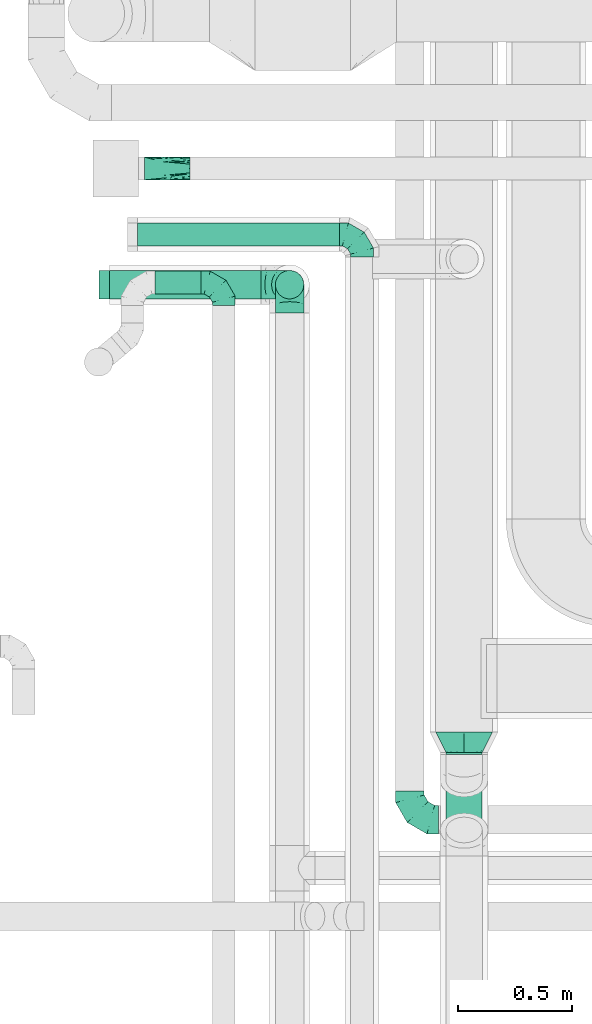
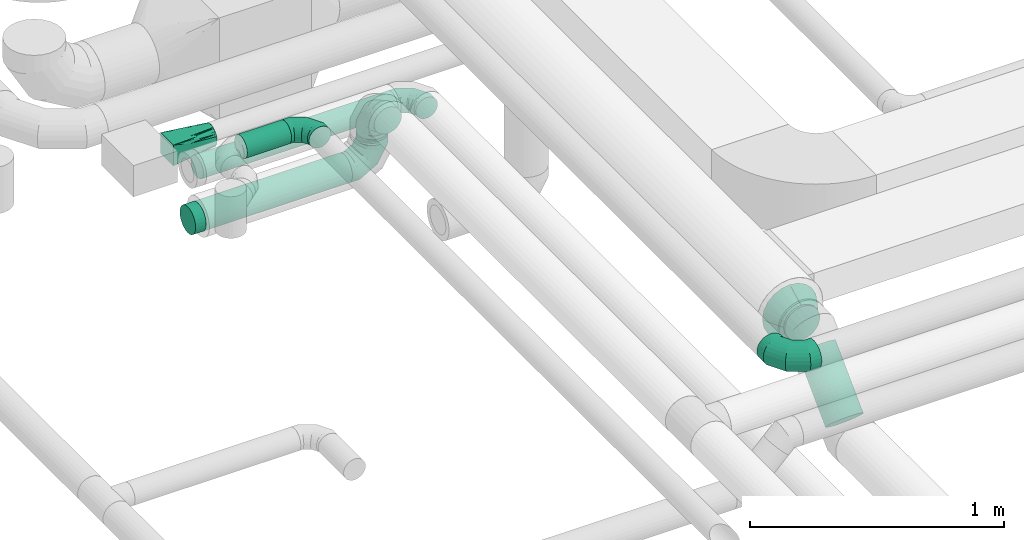
# One storey, part 67 of 92: 8 flow fittings, 6 flow segments.
"""IFC2X3 building model written with IfcOpenShell, lengths in millimetres."""

from ifc_helpers import new_model, entity, si_unit, converted_unit, derived_unit, direction, frame, origin, origin_2d_with_axis, place, context, subcontext, project, spatial, circle, extrude, faceted_brep, source, transform, mapped, material, type_object, type_shapes, element, save


model = new_model("IFC2X3")

# Units and contexts
model_context = context("Model", 3, precision=0.01, world=origin(), true_north=direction((6.12303176911189e-17, 1.0)))
body_context = subcontext(model_context, "Body", "Model", "MODEL_VIEW")
ifc_project = project(units=[si_unit("LENGTHUNIT", "METRE", prefix="MILLI"), si_unit("AREAUNIT", "SQUARE_METRE"), si_unit("VOLUMEUNIT", "CUBIC_METRE"), converted_unit("PLANEANGLEUNIT", "DEGREE", entity("IfcRatioMeasure", 0.0174532925199433), si_unit("PLANEANGLEUNIT", "RADIAN"), dimensions=[0, 0, 0, 0, 0, 0, 0]), si_unit("MASSUNIT", "GRAM", prefix="KILO"), derived_unit("MASSDENSITYUNIT", [(si_unit("MASSUNIT", "GRAM", prefix="KILO"), 1), (si_unit("LENGTHUNIT", "METRE"), -3)]), derived_unit("MOMENTOFINERTIAUNIT", [(si_unit("LENGTHUNIT", "METRE"), 4)]), si_unit("TIMEUNIT", "SECOND"), si_unit("FREQUENCYUNIT", "HERTZ"), si_unit("THERMODYNAMICTEMPERATUREUNIT", "DEGREE_CELSIUS"), derived_unit("THERMALTRANSMITTANCEUNIT", [(si_unit("MASSUNIT", "GRAM", prefix="KILO"), 1), (si_unit("THERMODYNAMICTEMPERATUREUNIT", "KELVIN"), -1), (si_unit("TIMEUNIT", "SECOND"), -3)]), derived_unit("VOLUMETRICFLOWRATEUNIT", [(si_unit("LENGTHUNIT", "METRE"), 3), (si_unit("TIMEUNIT", "SECOND"), -1)]), derived_unit("MASSFLOWRATEUNIT", [(si_unit("MASSUNIT", "GRAM", prefix="KILO"), 1), (si_unit("TIMEUNIT", "SECOND"), -1)]), derived_unit("ROTATIONALFREQUENCYUNIT", [(si_unit("TIMEUNIT", "SECOND"), -1)]), si_unit("ELECTRICCURRENTUNIT", "AMPERE"), si_unit("ELECTRICVOLTAGEUNIT", "VOLT"), si_unit("POWERUNIT", "WATT"), si_unit("FORCEUNIT", "NEWTON", prefix="KILO"), si_unit("ILLUMINANCEUNIT", "LUX"), si_unit("LUMINOUSFLUXUNIT", "LUMEN"), si_unit("LUMINOUSINTENSITYUNIT", "CANDELA"), derived_unit("USERDEFINED", [(si_unit("MASSUNIT", "GRAM", prefix="KILO"), -1), (si_unit("LENGTHUNIT", "METRE"), -2), (si_unit("TIMEUNIT", "SECOND"), 3), (si_unit("LUMINOUSFLUXUNIT", "LUMEN"), 1)]), derived_unit("LINEARVELOCITYUNIT", [(si_unit("LENGTHUNIT", "METRE"), 1), (si_unit("TIMEUNIT", "SECOND"), -1)]), si_unit("PRESSUREUNIT", "PASCAL"), derived_unit("USERDEFINED", [(si_unit("LENGTHUNIT", "METRE"), -2), (si_unit("MASSUNIT", "GRAM", prefix="KILO"), 1), (si_unit("TIMEUNIT", "SECOND"), -2)]), derived_unit("LINEARFORCEUNIT", [(si_unit("MASSUNIT", "GRAM", prefix="KILO"), 1), (si_unit("LENGTHUNIT", "METRE"), 1), (si_unit("TIMEUNIT", "SECOND"), -2), (si_unit("LENGTHUNIT", "METRE"), -1)]), derived_unit("PLANARFORCEUNIT", [(si_unit("MASSUNIT", "GRAM", prefix="KILO"), 1), (si_unit("LENGTHUNIT", "METRE"), 1), (si_unit("TIMEUNIT", "SECOND"), -2), (si_unit("LENGTHUNIT", "METRE"), -2)])], contexts=[model_context])

# Site, building, storey
site_placement = place(None, origin())
site = spatial("IfcSite", under=ifc_project, at=site_placement, CompositionType="ELEMENT")
building_placement = place(site_placement, origin())
building = spatial("IfcBuilding", under=site, at=building_placement, CompositionType="ELEMENT")
storey_placement = place(building_placement, frame((0.0, 0.0, 4200.0)))
storey = spatial("IfcBuildingStorey", under=building, at=storey_placement, CompositionType="ELEMENT", Elevation=4200.0)

# Flow segments
duct_segment_type_1 = type_object("IfcDuctSegmentType", PredefinedType="NOTDEFINED")
flow_segment_1_placement = place(storey_placement, frame((59650.81, 11473.3, 3098.4)))
element("IfcFlowSegment", 1, at=flow_segment_1_placement, inside=storey, type_object=duct_segment_type_1, context=body_context, shape_type="SweptSolid", body=[
    extrude(circle(Radius=50.0, at=origin_2d_with_axis()), frame((0.0, 51.6, 51.6), z_axis=(1.0, 0.0, 0.0), x_axis=(0.0, 1.0, 0.0)), (0.0, 0.0, 1.0), 886.324534692973),
])
flow_segment_2_placement = place(storey_placement, frame((59528.94, 11240.09, 3025.9)))
element("IfcFlowSegment", 2, at=flow_segment_2_placement, inside=storey, type_object=duct_segment_type_1, context=body_context, shape_type="SweptSolid", body=[
    extrude(circle(Radius=62.5, at=origin_2d_with_axis()), frame((0.0, 64.1, 64.1), z_axis=(1.0, 0.0, 0.0), x_axis=(0.0, 1.0, 0.0)), (0.0, 0.0, 1.0), 665.012949999809),
])
flow_segment_3_placement = place(storey_placement, frame((61003.4, 9241.69, 3200.9)))
element("IfcFlowSegment", 3, at=flow_segment_3_placement, inside=storey, type_object=duct_segment_type_1, context=body_context, shape_type="SweptSolid", body=[
    extrude(circle(Radius=80.0, at=origin_2d_with_axis()), frame((81.6, 0.0, 81.6), z_axis=(0.0, 1.0, 0.0), x_axis=(-1.0, 0.0, 0.0)), (0.0, 0.0, 1.0), 9.44565002031431),
])
flow_segment_4_placement = place(storey_placement, frame((61003.4, 8851.62, 2958.7)))
element("IfcFlowSegment", 4, at=flow_segment_4_placement, inside=storey, type_object=duct_segment_type_1, context=body_context, shape_type="SweptSolid", body=[
    extrude(circle(Radius=80.0, at=origin_2d_with_axis()), frame((81.6, 58.16, 58.16), z_axis=(0.0, 0.707106781186505, 0.707106781186591), x_axis=(-1.0, 0.0, 0.0)), (0.0, 0.0, 1.0), 309.3933982822),
])
duct_segment_type_2 = type_object("IfcDuctSegmentType", PredefinedType="NOTDEFINED")
flow_segment_5_placement = place(storey_placement, frame((60254.86, 11240.09, 3215.0)))
element("IfcFlowSegment", 5, at=flow_segment_5_placement, inside=storey, type_object=duct_segment_type_2, context=body_context, shape_type="SweptSolid", body=[
    extrude(circle(Radius=62.5, at=origin_2d_with_axis()), frame((64.1, 64.1, 0.0), z_axis=(0.0, 0.0, 1.0), x_axis=(-1.0, 0.0, 0.0)), (0.0, 0.0, 1.0), 10.0000000000508),
])
flow_segment_6_placement = place(storey_placement, frame((59728.25, 11261.85, 3298.4)))
element("IfcFlowSegment", 6, at=flow_segment_6_placement, inside=storey, type_object=duct_segment_type_2, context=body_context, shape_type="SweptSolid", body=[
    extrude(circle(Radius=50.0, at=origin_2d_with_axis()), frame((0.0, 51.6, 51.6), z_axis=(1.0, 0.0, 0.0), x_axis=(0.0, 1.0, 0.0)), (0.0, 0.0, 1.0), 201.79999999998),
])

# Flow fittings
ifc_material = material()
duct_fitting_type_1 = type_object("IfcDuctFittingType", PredefinedType="NOTDEFINED", material=ifc_material)
shared_shape_1 = source(origin(), body_context, "Body", "Brep", [
    faceted_brep([(-100.0, 0.0, -50.0), (-100.0, -12.94, -48.3), (-100.0, -25.0, -43.3), (-100.0, -35.36, -35.36), (-100.0, -43.3, -25.0), (-100.0, -48.3, -12.94), (-100.0, -50.0, 0.0), (-100.0, -48.3, 12.94), (-100.0, -43.3, 25.0), (-100.0, -35.36, 35.36), (-100.0, -25.0, 43.3), (-100.0, -12.94, 48.3), (-100.0, 0.0, 50.0), (-100.0, 12.94, 48.3), (-100.0, 25.0, 43.3), (-100.0, 35.36, 35.36), (-100.0, 43.3, 25.0), (-100.0, 48.3, 12.94), (-100.0, 50.0, 0.0), (-100.0, 48.3, -12.94), (-100.0, 43.3, -25.0), (-100.0, 35.36, -35.36), (-100.0, 25.0, -43.3), (-100.0, 12.94, -48.3), (-76.67, 12.94, 48.3), (-79.9, 25.0, 43.3), (-73.21, 0.0, 50.0), (-82.68, 35.36, 35.36), (-86.15, 48.3, 12.94), (-86.6, 50.0, 0.0), (-84.81, 43.3, 25.0), (-84.81, 43.3, -25.0), (-82.68, 35.36, -35.36), (-86.15, 48.3, -12.94), (-76.67, 12.94, -48.3), (-73.21, 0.0, -50.0), (-79.9, 25.0, -43.3), (-69.74, -12.94, -48.3), (-66.51, -25.0, -43.3), (-63.73, -35.36, -35.36), (-61.6, -43.3, -25.0), (-60.26, -48.3, -12.94), (-59.81, -50.0, 0.0), (-60.26, -48.3, 12.94), (-61.6, -43.3, 25.0), (-63.73, -35.36, 35.36), (-66.51, -25.0, 43.3), (-69.74, -12.94, 48.3), (-36.27, 36.27, 48.3), (-45.1, 45.1, 43.3), (-26.79, 26.79, 50.0), (-52.68, 52.68, 35.36), (-58.49, 58.49, 25.0), (-62.15, 62.15, 12.94), (-63.4, 63.4, 0.0), (-62.15, 62.15, -12.94), (-58.49, 58.49, -25.0), (-52.68, 52.68, -35.36), (-36.27, 36.27, -48.3), (-26.79, 26.79, -50.0), (-45.1, 45.1, -43.3), (-17.32, 17.32, -48.3), (-8.49, 8.49, -43.3), (-0.91, 0.91, -35.36), (4.9, -4.9, -25.0), (8.56, -8.56, -12.94), (9.81, -9.81, 0.0), (8.56, -8.56, 12.94), (4.9, -4.9, 25.0), (-0.91, 0.91, 35.36), (-8.49, 8.49, 43.3), (-17.32, 17.32, 48.3), (-12.94, 76.67, 48.3), (-25.0, 79.9, 43.3), (0.0, 73.21, 50.0), (-35.36, 82.68, 35.36), (-43.3, 84.81, 25.0), (-48.3, 86.15, 12.94), (-50.0, 86.6, 0.0), (-48.3, 86.15, -12.94), (-43.3, 84.81, -25.0), (-35.36, 82.68, -35.36), (-12.94, 76.67, -48.3), (0.0, 73.21, -50.0), (-25.0, 79.9, -43.3), (12.94, 69.74, -48.3), (25.0, 66.51, -43.3), (35.36, 63.73, -35.36), (43.3, 61.6, -25.0), (48.3, 60.26, -12.94), (50.0, 59.81, 0.0), (48.3, 60.26, 12.94), (43.3, 61.6, 25.0), (35.36, 63.73, 35.36), (25.0, 66.51, 43.3), (12.94, 69.74, 48.3), (-12.94, 100.0, -48.3), (-25.0, 100.0, -43.3), (-35.36, 100.0, -35.36), (-43.3, 100.0, -25.0), (-48.3, 100.0, -12.94), (-50.0, 100.0, 0.0), (-48.3, 100.0, 12.94), (-43.3, 100.0, 25.0), (-35.36, 100.0, 35.36), (-25.0, 100.0, 43.3), (-12.94, 100.0, 48.3), (0.0, 100.0, 50.0), (12.94, 100.0, 48.3), (25.0, 100.0, 43.3), (35.36, 100.0, 35.36), (43.3, 100.0, 25.0), (48.3, 100.0, 12.94), (50.0, 100.0, 0.0), (48.3, 100.0, -12.94), (43.3, 100.0, -25.0), (35.36, 100.0, -35.36), (25.0, 100.0, -43.3), (12.94, 100.0, -48.3), (0.0, 100.0, -50.0)], [[[0, 1, 2, 3, 4, 5, 6, 7, 8, 9, 10, 11, 12, 13, 14, 15, 16, 17, 18, 19, 20, 21, 22, 23]], [[24, 25, 14, 13]], [[26, 24, 13, 12]], [[14, 25, 27, 15]], [[28, 29, 18, 17]], [[30, 28, 17, 16]], [[15, 27, 30, 16]], [[20, 31, 32, 21]], [[33, 31, 20, 19]], [[18, 29, 33, 19]], [[34, 35, 0, 23]], [[36, 34, 23, 22]], [[32, 36, 22, 21]], [[2, 1, 37, 38]], [[3, 2, 38, 39]], [[0, 35, 37, 1]], [[5, 4, 40, 41]], [[6, 5, 41, 42]], [[3, 39, 40, 4]], [[6, 42, 43, 7]], [[7, 43, 44, 8]], [[8, 44, 45, 9]], [[10, 46, 47, 11]], [[11, 47, 26, 12]], [[10, 9, 45, 46]], [[48, 49, 25, 24]], [[50, 48, 24, 26]], [[27, 25, 49, 51]], [[52, 53, 28, 30]], [[51, 52, 30, 27]], [[29, 28, 53, 54]], [[55, 56, 31, 33]], [[54, 55, 33, 29]], [[57, 32, 31, 56]], [[58, 59, 35, 34]], [[60, 58, 34, 36]], [[57, 60, 36, 32]], [[37, 35, 59, 61]], [[38, 37, 61, 62]], [[39, 38, 62, 63]], [[41, 40, 64, 65]], [[42, 41, 65, 66]], [[63, 64, 40, 39]], [[43, 42, 66, 67]], [[44, 43, 67, 68]], [[68, 69, 45, 44]], [[46, 45, 69, 70]], [[47, 46, 70, 71]], [[26, 47, 71, 50]], [[72, 73, 49, 48]], [[74, 72, 48, 50]], [[51, 49, 73, 75]], [[76, 77, 53, 52]], [[75, 76, 52, 51]], [[54, 53, 77, 78]], [[79, 80, 56, 55]], [[78, 79, 55, 54]], [[81, 57, 56, 80]], [[82, 83, 59, 58]], [[84, 82, 58, 60]], [[81, 84, 60, 57]], [[61, 59, 83, 85]], [[62, 61, 85, 86]], [[63, 62, 86, 87]], [[65, 64, 88, 89]], [[66, 65, 89, 90]], [[87, 88, 64, 63]], [[67, 66, 90, 91]], [[68, 67, 91, 92]], [[92, 93, 69, 68]], [[70, 69, 93, 94]], [[71, 70, 94, 95]], [[50, 71, 95, 74]], [[96, 97, 98, 99, 100, 101, 102, 103, 104, 105, 106, 107, 108, 109, 110, 111, 112, 113, 114, 115, 116, 117, 118, 119]], [[72, 74, 107, 106]], [[73, 72, 106, 105]], [[75, 73, 105, 104]], [[77, 76, 103, 102]], [[78, 77, 102, 101]], [[75, 104, 103, 76]], [[78, 101, 100, 79]], [[79, 100, 99, 80]], [[80, 99, 98, 81]], [[96, 119, 83, 82]], [[97, 96, 82, 84]], [[84, 81, 98, 97]], [[83, 119, 118, 85]], [[85, 118, 117, 86]], [[86, 117, 116, 87]], [[88, 115, 114, 89]], [[89, 114, 113, 90]], [[87, 116, 115, 88]], [[91, 90, 113, 112]], [[92, 91, 112, 111]], [[93, 92, 111, 110]], [[95, 94, 109, 108]], [[74, 95, 108, 107]], [[110, 109, 94, 93]]]),
])
type_shapes(duct_fitting_type_1, [shared_shape_1])
for number, where, z_axis, x_axis in (
    (7, (60030.05, 11313.45, 3350.0), (0.0, 0.0, 1.0), (0.0, 1.0, 0.0)),
    (8, (60637.13, 11524.89, 3150.0), (0.0, 0.0, 1.0), (0.0, 1.0, 0.0)),
):
    element("IfcFlowFitting", number, at=place(storey_placement, frame(where, z_axis=z_axis, x_axis=x_axis)), inside=storey, type_object=duct_fitting_type_1, material=ifc_material, context=body_context, shape_type="MappedRepresentation", body=[
        mapped(shared_shape_1, transform((0.0, 0.0, 0.0), scale=1.0)),
    ])
duct_fitting_type_2 = type_object("IfcDuctFittingType", PredefinedType="NOTDEFINED", material=ifc_material)
shared_shape_2 = source(origin(), body_context, "Body", "Brep", [
    faceted_brep([(-125.0, 0.0, -62.5), (-125.0, -16.18, -60.37), (-125.0, -31.25, -54.13), (-125.0, -44.19, -44.19), (-125.0, -54.13, -31.25), (-125.0, -60.37, -16.18), (-125.0, -62.5, 0.0), (-125.0, -60.37, 16.18), (-125.0, -54.13, 31.25), (-125.0, -44.19, 44.19), (-125.0, -31.25, 54.13), (-125.0, -16.18, 60.37), (-125.0, 0.0, 62.5), (-125.0, 16.18, 60.37), (-125.0, 31.25, 54.13), (-125.0, 44.19, 44.19), (-125.0, 54.13, 31.25), (-125.0, 60.37, 16.18), (-125.0, 62.5, 0.0), (-125.0, 60.37, -16.18), (-125.0, 54.13, -31.25), (-125.0, 44.19, -44.19), (-125.0, 31.25, -54.13), (-125.0, 16.18, -60.37), (-95.84, 16.18, 60.37), (-99.88, 31.25, 54.13), (-91.51, 0.0, 62.5), (-103.35, 44.19, 44.19), (-107.68, 60.37, 16.18), (-108.25, 62.5, 0.0), (-106.01, 54.13, 31.25), (-106.01, 54.13, -31.25), (-103.35, 44.19, -44.19), (-107.68, 60.37, -16.18), (-95.84, 16.18, -60.37), (-91.51, 0.0, -62.5), (-99.88, 31.25, -54.13), (-87.17, -16.18, -60.37), (-83.13, -31.25, -54.13), (-79.66, -44.19, -44.19), (-77.0, -54.13, -31.25), (-75.33, -60.37, -16.18), (-74.76, -62.5, 0.0), (-75.33, -60.37, 16.18), (-77.0, -54.13, 31.25), (-79.66, -44.19, 44.19), (-83.13, -31.25, 54.13), (-87.17, -16.18, 60.37), (-45.34, 45.34, 60.37), (-56.37, 56.37, 54.13), (-33.49, 33.49, 62.5), (-65.85, 65.85, 44.19), (-73.12, 73.12, 31.25), (-77.69, 77.69, 16.18), (-79.25, 79.25, 0.0), (-77.69, 77.69, -16.18), (-73.12, 73.12, -31.25), (-65.85, 65.85, -44.19), (-45.34, 45.34, -60.37), (-33.49, 33.49, -62.5), (-56.37, 56.37, -54.13), (-21.65, 21.65, -60.37), (-10.62, 10.62, -54.13), (-1.14, 1.14, -44.19), (6.13, -6.13, -31.25), (10.7, -10.7, -16.18), (12.26, -12.26, 0.0), (10.7, -10.7, 16.18), (6.13, -6.13, 31.25), (-1.14, 1.14, 44.19), (-10.62, 10.62, 54.13), (-21.65, 21.65, 60.37), (-16.18, 95.84, 60.37), (-31.25, 99.88, 54.13), (0.0, 91.51, 62.5), (-44.19, 103.35, 44.19), (-54.13, 106.01, 31.25), (-60.37, 107.68, 16.18), (-62.5, 108.25, 0.0), (-60.37, 107.68, -16.18), (-54.13, 106.01, -31.25), (-44.19, 103.35, -44.19), (-16.18, 95.84, -60.37), (0.0, 91.51, -62.5), (-31.25, 99.88, -54.13), (16.18, 87.17, -60.37), (31.25, 83.13, -54.13), (44.19, 79.66, -44.19), (54.13, 77.0, -31.25), (60.37, 75.33, -16.18), (62.5, 74.76, 0.0), (60.37, 75.33, 16.18), (54.13, 77.0, 31.25), (44.19, 79.66, 44.19), (31.25, 83.13, 54.13), (16.18, 87.17, 60.37), (-16.18, 125.0, -60.37), (-31.25, 125.0, -54.13), (-44.19, 125.0, -44.19), (-54.13, 125.0, -31.25), (-60.37, 125.0, -16.18), (-62.5, 125.0, 0.0), (-60.37, 125.0, 16.18), (-54.13, 125.0, 31.25), (-44.19, 125.0, 44.19), (-31.25, 125.0, 54.13), (-16.18, 125.0, 60.37), (0.0, 125.0, 62.5), (16.18, 125.0, 60.37), (31.25, 125.0, 54.13), (44.19, 125.0, 44.19), (54.13, 125.0, 31.25), (60.37, 125.0, 16.18), (62.5, 125.0, 0.0), (60.37, 125.0, -16.18), (54.13, 125.0, -31.25), (44.19, 125.0, -44.19), (31.25, 125.0, -54.13), (16.18, 125.0, -60.37), (0.0, 125.0, -62.5)], [[[0, 1, 2, 3, 4, 5, 6, 7, 8, 9, 10, 11, 12, 13, 14, 15, 16, 17, 18, 19, 20, 21, 22, 23]], [[24, 25, 14, 13]], [[26, 24, 13, 12]], [[14, 25, 27, 15]], [[28, 29, 18, 17]], [[30, 28, 17, 16]], [[15, 27, 30, 16]], [[20, 31, 32, 21]], [[33, 31, 20, 19]], [[18, 29, 33, 19]], [[34, 35, 0, 23]], [[36, 34, 23, 22]], [[21, 32, 36, 22]], [[1, 0, 35, 37]], [[2, 1, 37, 38]], [[38, 39, 3, 2]], [[5, 4, 40, 41]], [[6, 5, 41, 42]], [[39, 40, 4, 3]], [[6, 42, 43, 7]], [[7, 43, 44, 8]], [[45, 9, 8, 44]], [[9, 45, 46, 10]], [[10, 46, 47, 11]], [[26, 12, 11, 47]], [[48, 49, 25, 24]], [[50, 48, 24, 26]], [[27, 25, 49, 51]], [[52, 53, 28, 30]], [[51, 52, 30, 27]], [[29, 28, 53, 54]], [[55, 56, 31, 33]], [[54, 55, 33, 29]], [[57, 32, 31, 56]], [[58, 59, 35, 34]], [[60, 58, 34, 36]], [[57, 60, 36, 32]], [[37, 35, 59, 61]], [[38, 37, 61, 62]], [[39, 38, 62, 63]], [[41, 40, 64, 65]], [[42, 41, 65, 66]], [[63, 64, 40, 39]], [[43, 42, 66, 67]], [[44, 43, 67, 68]], [[68, 69, 45, 44]], [[46, 45, 69, 70]], [[47, 46, 70, 71]], [[26, 47, 71, 50]], [[72, 73, 49, 48]], [[74, 72, 48, 50]], [[51, 49, 73, 75]], [[76, 77, 53, 52]], [[75, 76, 52, 51]], [[54, 53, 77, 78]], [[79, 80, 56, 55]], [[78, 79, 55, 54]], [[81, 57, 56, 80]], [[82, 83, 59, 58]], [[84, 82, 58, 60]], [[81, 84, 60, 57]], [[61, 59, 83, 85]], [[62, 61, 85, 86]], [[63, 62, 86, 87]], [[65, 64, 88, 89]], [[66, 65, 89, 90]], [[87, 88, 64, 63]], [[67, 66, 90, 91]], [[68, 67, 91, 92]], [[92, 93, 69, 68]], [[70, 69, 93, 94]], [[71, 70, 94, 95]], [[50, 71, 95, 74]], [[96, 97, 98, 99, 100, 101, 102, 103, 104, 105, 106, 107, 108, 109, 110, 111, 112, 113, 114, 115, 116, 117, 118, 119]], [[72, 74, 107, 106]], [[73, 72, 106, 105]], [[75, 73, 105, 104]], [[77, 76, 103, 102]], [[78, 77, 102, 101]], [[75, 104, 103, 76]], [[78, 101, 100, 79]], [[79, 100, 99, 80]], [[80, 99, 98, 81]], [[96, 119, 83, 82]], [[97, 96, 82, 84]], [[84, 81, 98, 97]], [[83, 119, 118, 85]], [[85, 118, 117, 86]], [[116, 87, 86, 117]], [[88, 115, 114, 89]], [[89, 114, 113, 90]], [[115, 88, 87, 116]], [[91, 90, 113, 112]], [[92, 91, 112, 111]], [[111, 110, 93, 92]], [[95, 94, 109, 108]], [[74, 95, 108, 107]], [[110, 109, 94, 93]]]),
])
type_shapes(duct_fitting_type_2, [shared_shape_2])
for number, where, z_axis, x_axis in (
    (9, (60318.95, 11304.18, 3350.0), (1.0, 0.0, 0.0), (0.0, 0.0, 1.0)),
    (10, (60847.39, 8955.15, 3350.0), (0.0, 0.0, 1.0), (0.0, -1.0, 0.0)),
    (11, (60318.95, 11304.18, 3090.0), (0.0, 1.0, 0.0), (0.0, 0.0, -1.0)),
):
    element("IfcFlowFitting", number, at=place(storey_placement, frame(where, z_axis=z_axis, x_axis=x_axis)), inside=storey, type_object=duct_fitting_type_2, material=ifc_material, context=body_context, shape_type="MappedRepresentation", body=[
        mapped(shared_shape_2, transform((0.0, 0.0, 0.0), scale=1.0)),
    ])
duct_fitting_type_3 = type_object("IfcDuctFittingType", PredefinedType="NOTDEFINED", material=ifc_material)
shared_shape_3 = source(origin(), body_context, "Body", "Brep", [
    faceted_brep([(20.0, 16.18, -60.37), (20.0, 31.25, -54.13), (20.0, 44.19, -44.19), (20.0, 54.13, -31.25), (20.0, 60.37, -16.18), (20.0, 62.5, 0.0), (20.0, 60.37, 16.18), (20.0, 54.13, 31.25), (20.0, 44.19, 44.19), (20.0, 31.25, 54.13), (20.0, 16.18, 60.37), (20.0, 0.0, 62.5), (20.0, -16.18, 60.37), (20.0, -31.25, 54.13), (20.0, -44.19, 44.19), (20.0, -54.13, 31.25), (20.0, -60.37, 16.18), (20.0, -62.5, 0.0), (20.0, -60.37, -16.18), (20.0, -54.13, -31.25), (20.0, -44.19, -44.19), (20.0, -31.25, -54.13), (20.0, -16.18, -60.37), (20.0, 0.0, -62.5), (0.0, 0.0, 62.5), (0.0, 16.18, 60.37), (-28.03, 16.18, 60.37), (-28.03, 0.0, 62.5), (0.0, 31.25, 54.13), (-28.03, 31.25, 54.13), (0.0, 44.19, 44.19), (-28.03, 44.19, 44.19), (0.0, 54.13, 31.25), (0.0, 60.37, 16.18), (-28.03, 60.37, 16.18), (-28.03, 54.13, 31.25), (0.0, 62.5, 0.0), (-28.03, 62.5, 0.0), (0.0, 60.37, -16.18), (-28.03, 60.37, -16.18), (0.0, 54.13, -31.25), (-28.03, 54.13, -31.25), (0.0, 44.19, -44.19), (-28.03, 44.19, -44.19), (0.0, 31.25, -54.13), (0.0, 16.18, -60.37), (-28.03, 16.18, -60.37), (-28.03, 31.25, -54.13), (0.0, 0.0, -62.5), (-28.03, 0.0, -62.5), (0.0, -16.18, -60.37), (-28.03, -16.18, -60.37), (0.0, -31.25, -54.13), (-28.03, -31.25, -54.13), (0.0, -44.19, -44.19), (-28.03, -44.19, -44.19), (0.0, -54.13, -31.25), (0.0, -60.37, -16.18), (-28.03, -60.37, -16.18), (-28.03, -54.13, -31.25), (0.0, -62.5, 0.0), (-28.03, -62.5, 0.0), (0.0, -60.37, 16.18), (-28.03, -60.37, 16.18), (0.0, -54.13, 31.25), (-28.03, -54.13, 31.25), (0.0, -44.19, 44.19), (-28.03, -44.19, 44.19), (0.0, -31.25, 54.13), (0.0, -16.18, 60.37), (-28.03, -16.18, 60.37), (-28.03, -31.25, 54.13)], [[[0, 1, 2, 3, 4, 5, 6, 7, 8, 9, 10, 11, 12, 13, 14, 15, 16, 17, 18, 19, 20, 21, 22, 23]], [[24, 11, 10, 25, 26, 27]], [[25, 10, 9, 28, 29, 26]], [[28, 9, 8, 30, 31, 29]], [[32, 7, 6, 33, 34, 35]], [[33, 6, 5, 36, 37, 34]], [[30, 8, 7, 32, 35, 31]], [[36, 5, 4, 38, 39, 37]], [[38, 4, 3, 40, 41, 39]], [[40, 3, 2, 42, 43, 41]], [[44, 1, 0, 45, 46, 47]], [[45, 0, 23, 48, 49, 46]], [[42, 2, 1, 44, 47, 43]], [[48, 23, 22, 50, 51, 49]], [[50, 22, 21, 52, 53, 51]], [[52, 21, 20, 54, 55, 53]], [[56, 19, 18, 57, 58, 59]], [[57, 18, 17, 60, 61, 58]], [[54, 20, 19, 56, 59, 55]], [[60, 17, 16, 62, 63, 61]], [[62, 16, 15, 64, 65, 63]], [[64, 15, 14, 66, 67, 65]], [[68, 13, 12, 69, 70, 71]], [[69, 12, 11, 24, 27, 70]], [[66, 14, 13, 68, 71, 67]], [[49, 51, 53, 55, 59, 58, 61, 63, 65, 67, 71, 70, 27, 26, 29, 31, 35, 34, 37, 39, 41, 43, 47, 46]]]),
])
type_shapes(duct_fitting_type_3, [shared_shape_3])
flow_fitting_1_placement = place(storey_placement, frame((59508.94, 11304.18, 3090.0), z_axis=(0.0, -1.0, 0.0), x_axis=(1.0, 0.0, 0.0)))
element("IfcFlowFitting", 12, at=flow_fitting_1_placement, inside=storey, type_object=duct_fitting_type_3, material=ifc_material, context=body_context, shape_type="MappedRepresentation", body=[
    mapped(shared_shape_3, transform((0.0, 0.0, 0.0), scale=1.0)),
])
duct_fitting_type_4 = type_object("IfcDuctFittingType", PredefinedType="NOTDEFINED", material=ifc_material)
shared_shape_4 = source(origin(), body_context, "Body", "Brep", [
    faceted_brep([(200.0, -3.06, 49.39), (200.0, -6.12, 48.78), (200.0, -12.24, 47.57), (200.0, -19.13, 46.19), (200.0, -23.19, 43.48), (200.0, -27.24, 40.77), (200.0, -31.3, 38.06), (200.0, -35.36, 35.36), (200.0, -38.06, 31.3), (200.0, -40.77, 27.24), (200.0, -43.48, 23.19), (200.0, -46.19, 19.13), (200.0, -47.57, 12.24), (200.0, -48.78, 6.12), (200.0, -49.39, 3.06), (200.0, -50.0, 0.0), (200.0, -49.39, -3.06), (200.0, -48.78, -6.12), (200.0, -47.57, -12.24), (200.0, -46.19, -19.13), (200.0, -43.48, -23.19), (200.0, -40.77, -27.24), (200.0, -38.06, -31.3), (200.0, -35.36, -35.36), (200.0, -31.3, -38.06), (200.0, -27.24, -40.77), (200.0, -23.19, -43.48), (200.0, -19.13, -46.19), (200.0, -12.24, -47.57), (200.0, -6.12, -48.78), (200.0, -3.06, -49.39), (200.0, 0.0, -50.0), (200.0, 3.06, -49.39), (200.0, 6.12, -48.78), (200.0, 12.24, -47.57), (200.0, 19.13, -46.19), (200.0, 23.19, -43.48), (200.0, 27.24, -40.77), (200.0, 31.3, -38.06), (200.0, 35.36, -35.36), (200.0, 38.06, -31.3), (200.0, 40.77, -27.24), (200.0, 43.48, -23.19), (200.0, 46.19, -19.13), (200.0, 47.57, -12.24), (200.0, 48.78, -6.12), (200.0, 49.39, -3.06), (200.0, 50.0, 0.0), (200.0, 49.39, 3.06), (200.0, 48.78, 6.12), (200.0, 47.57, 12.24), (200.0, 46.19, 19.13), (200.0, 43.48, 23.19), (200.0, 40.77, 27.24), (200.0, 38.06, 31.3), (200.0, 35.36, 35.36), (200.0, 31.3, 38.06), (200.0, 27.24, 40.77), (200.0, 23.19, 43.48), (200.0, 19.13, 46.19), (200.0, 12.24, 47.57), (200.0, 6.12, 48.78), (200.0, 3.06, 49.39), (200.0, 0.0, 50.0), (0.0, -50.0, 50.0), (0.0, 50.0, 50.0), (0.0, 50.0, -50.0), (0.0, -50.0, -50.0), (184.77, -3.81, 50.0), (169.54, -7.62, 50.0), (139.08, -15.23, 50.0), (108.61, -22.85, 50.0), (78.15, -30.46, 50.0), (39.08, -40.23, 50.0), (121.32, -38.12, 43.74), (118.13, -33.98, 46.73), (78.15, -50.0, 30.46), (108.61, -50.0, 22.85), (139.08, -50.0, 15.23), (169.54, -50.0, 7.62), (184.77, -50.0, 3.81), (100.0, -44.18, 41.04), (124.23, -45.44, 35.14), (39.08, -50.0, 40.23), (39.08, -50.0, -40.23), (78.15, -50.0, -30.46), (108.61, -50.0, -22.85), (139.08, -50.0, -15.23), (169.54, -50.0, -7.62), (184.77, -50.0, -3.81), (121.32, -43.74, -38.12), (118.13, -46.73, -33.98), (78.15, -30.46, -50.0), (108.61, -22.85, -50.0), (139.08, -15.23, -50.0), (169.54, -7.62, -50.0), (184.77, -3.81, -50.0), (100.0, -41.04, -44.18), (124.23, -35.14, -45.44), (39.08, -40.23, -50.0), (39.08, 40.23, -50.0), (78.15, 30.46, -50.0), (108.61, 22.85, -50.0), (139.08, 15.23, -50.0), (169.54, 7.62, -50.0), (184.77, 3.81, -50.0), (121.32, 38.12, -43.74), (118.13, 33.98, -46.73), (78.15, 50.0, -30.46), (108.61, 50.0, -22.85), (139.08, 50.0, -15.23), (169.54, 50.0, -7.62), (184.77, 50.0, -3.81), (100.0, 44.18, -41.04), (124.23, 45.44, -35.14), (39.08, 50.0, -40.23), (39.08, 50.0, 40.23), (78.15, 50.0, 30.46), (108.61, 50.0, 22.85), (139.08, 50.0, 15.23), (169.54, 50.0, 7.62), (184.77, 50.0, 3.81), (121.32, 43.74, 38.12), (118.13, 46.73, 33.98), (78.15, 30.46, 50.0), (108.61, 22.85, 50.0), (139.08, 15.23, 50.0), (169.54, 7.62, 50.0), (184.77, 3.81, 50.0), (100.0, 41.04, 44.18), (124.23, 35.14, 45.44), (39.08, 40.23, 50.0)], [[[0, 1, 2, 3, 4, 5, 6, 7, 8, 9, 10, 11, 12, 13, 14, 15, 16, 17, 18, 19, 20, 21, 22, 23, 24, 25, 26, 27, 28, 29, 30, 31, 32, 33, 34, 35, 36, 37, 38, 39, 40, 41, 42, 43, 44, 45, 46, 47, 48, 49, 50, 51, 52, 53, 54, 55, 56, 57, 58, 59, 60, 61, 62, 63]], [[64, 65, 66, 67]], [[3, 2, 1, 0, 63, 68, 69, 70, 71, 72]], [[73, 64, 74]], [[75, 4, 72]], [[12, 11, 76, 77, 78, 79, 80, 15, 14, 13]], [[75, 73, 74]], [[81, 82, 8]], [[10, 9, 76, 11]], [[81, 74, 64]], [[83, 81, 64]], [[9, 82, 76]], [[82, 81, 83]], [[81, 7, 74]], [[75, 6, 5, 4]], [[6, 75, 74]], [[72, 73, 75]], [[76, 82, 83]], [[8, 7, 81]], [[82, 9, 8]], [[4, 3, 72]], [[74, 7, 6]], [[80, 79, 78, 77, 76, 83, 64, 67, 84, 85, 86, 87, 88, 89, 15]], [[19, 18, 17, 16, 15, 89, 88, 87, 86, 85]], [[84, 67, 90]], [[91, 20, 85]], [[28, 27, 92, 93, 94, 95, 96, 31, 30, 29]], [[91, 84, 90]], [[97, 98, 24]], [[26, 25, 92, 27]], [[97, 90, 67]], [[99, 97, 67]], [[25, 98, 92]], [[98, 97, 99]], [[97, 23, 90]], [[91, 22, 21, 20]], [[22, 91, 90]], [[85, 84, 91]], [[92, 98, 99]], [[24, 23, 97]], [[98, 25, 24]], [[20, 19, 85]], [[90, 23, 22]], [[96, 95, 94, 93, 92, 99, 67, 66, 100, 101, 102, 103, 104, 105, 31]], [[35, 34, 33, 32, 31, 105, 104, 103, 102, 101]], [[100, 66, 106]], [[107, 36, 101]], [[44, 43, 108, 109, 110, 111, 112, 47, 46, 45]], [[107, 100, 106]], [[113, 114, 40]], [[42, 41, 108, 43]], [[113, 106, 66]], [[115, 113, 66]], [[41, 114, 108]], [[114, 113, 115]], [[113, 39, 106]], [[107, 38, 37, 36]], [[38, 107, 106]], [[101, 100, 107]], [[108, 114, 115]], [[40, 39, 113]], [[114, 41, 40]], [[36, 35, 101]], [[106, 39, 38]], [[66, 65, 116, 117, 118, 119, 120, 121, 47, 112, 111, 110, 109, 108, 115]], [[51, 50, 49, 48, 47, 121, 120, 119, 118, 117]], [[116, 65, 122]], [[123, 52, 117]], [[60, 59, 124, 125, 126, 127, 128, 63, 62, 61]], [[123, 116, 122]], [[129, 130, 56]], [[58, 57, 124, 59]], [[129, 122, 65]], [[131, 129, 65]], [[57, 130, 124]], [[130, 129, 131]], [[129, 55, 122]], [[123, 54, 53, 52]], [[54, 123, 122]], [[117, 116, 123]], [[124, 130, 131]], [[56, 55, 129]], [[130, 57, 56]], [[52, 51, 117]], [[122, 55, 54]], [[65, 64, 73, 72, 71, 70, 69, 68, 63, 128, 127, 126, 125, 124, 131]]]),
])
type_shapes(duct_fitting_type_4, [shared_shape_4])
flow_fitting_2_placement = place(storey_placement, frame((59680.69, 11814.2, 3050.0)))
element("IfcFlowFitting", 13, at=flow_fitting_2_placement, inside=storey, type_object=duct_fitting_type_4, material=ifc_material, context=body_context, shape_type="MappedRepresentation", body=[
    mapped(shared_shape_4, transform((0.0, 0.0, 0.0), scale=1.0)),
])
duct_fitting_type_5 = type_object("IfcDuctFittingType", PredefinedType="NOTDEFINED", material=ifc_material)
shared_shape_5 = source(origin(), body_context, "Body", "Brep", [
    faceted_brep([(90.0, -73.47, -101.13), (90.0, -38.63, -118.88), (90.0, 0.0, -125.0), (90.0, 38.63, -118.88), (90.0, 73.47, -101.13), (90.0, 101.13, -73.47), (90.0, 118.88, -38.63), (90.0, 125.0, 0.0), (90.0, 118.88, 38.63), (90.0, 101.13, 73.47), (90.0, 73.47, 101.13), (90.0, 38.63, 118.88), (90.0, 0.0, 125.0), (90.0, -38.63, 118.88), (90.0, -73.47, 101.13), (90.0, -101.13, 73.47), (90.0, -118.88, 38.63), (90.0, -125.0, 0.0), (90.0, -118.88, -38.63), (90.0, -101.13, -73.47), (0.0, -30.61, -73.91), (0.0, -43.59, -65.24), (0.0, -56.57, -56.57), (0.0, -65.24, -43.59), (0.0, -73.91, -30.61), (0.0, -76.96, -15.31), (0.0, -80.0, 0.0), (0.0, -76.96, 15.31), (0.0, -73.91, 30.61), (0.0, -65.24, 43.59), (0.0, -56.57, 56.57), (0.0, -43.59, 65.24), (0.0, -30.61, 73.91), (0.0, -15.31, 76.96), (0.0, 0.0, 80.0), (0.0, 15.31, 76.96), (0.0, 30.61, 73.91), (0.0, 43.59, 65.24), (0.0, 56.57, 56.57), (0.0, 65.24, 43.59), (0.0, 73.91, 30.61), (0.0, 76.96, 15.31), (0.0, 80.0, 0.0), (0.0, 76.96, -15.31), (0.0, 73.91, -30.61), (0.0, 65.24, -43.59), (0.0, 56.57, -56.57), (0.0, 43.59, -65.24), (0.0, 30.61, -73.91), (0.0, 15.31, -76.96), (0.0, 0.0, -80.0), (0.0, -15.31, -76.96)], [[[0, 1, 2, 3, 4, 5, 6, 7, 8, 9, 10, 11, 12, 13, 14, 15, 16, 17, 18, 19]], [[20, 21, 22, 23, 24, 25, 26, 27, 28, 29, 30, 31, 32, 33, 34, 35, 36, 37, 38, 39, 40, 41, 42, 43, 44, 45, 46, 47, 48, 49, 50, 51]], [[7, 41, 8]], [[41, 40, 8]], [[40, 9, 8]], [[11, 36, 35]], [[41, 7, 42]], [[9, 40, 39, 38]], [[10, 38, 37, 36]], [[12, 35, 34]], [[11, 10, 36]], [[12, 11, 35]], [[38, 10, 9]], [[12, 33, 13]], [[33, 32, 13]], [[32, 14, 13]], [[16, 28, 27]], [[33, 12, 34]], [[14, 32, 31, 30]], [[15, 30, 29, 28]], [[17, 27, 26]], [[16, 15, 28]], [[17, 16, 27]], [[30, 15, 14]], [[17, 25, 18]], [[25, 24, 18]], [[24, 19, 18]], [[1, 20, 51]], [[25, 17, 26]], [[19, 24, 23, 22]], [[0, 22, 21, 20]], [[2, 51, 50]], [[1, 0, 20]], [[2, 1, 51]], [[22, 0, 19]], [[2, 49, 3]], [[49, 48, 3]], [[48, 4, 3]], [[6, 44, 43]], [[49, 2, 50]], [[4, 48, 47, 46]], [[5, 46, 45, 44]], [[7, 43, 42]], [[6, 5, 44]], [[7, 6, 43]], [[46, 5, 4]]]),
])
type_shapes(duct_fitting_type_5, [shared_shape_5])
flow_fitting_3_placement = place(storey_placement, frame((61085.0, 9251.14, 3282.5), z_axis=(0.0, 0.0, 1.0), x_axis=(0.0, 1.0, 0.0)))
element("IfcFlowFitting", 14, at=flow_fitting_3_placement, inside=storey, type_object=duct_fitting_type_5, material=ifc_material, context=body_context, shape_type="MappedRepresentation", body=[
    mapped(shared_shape_5, transform((0.0, 0.0, 0.0), scale=1.0)),
])

save(model, "model.ifc")
